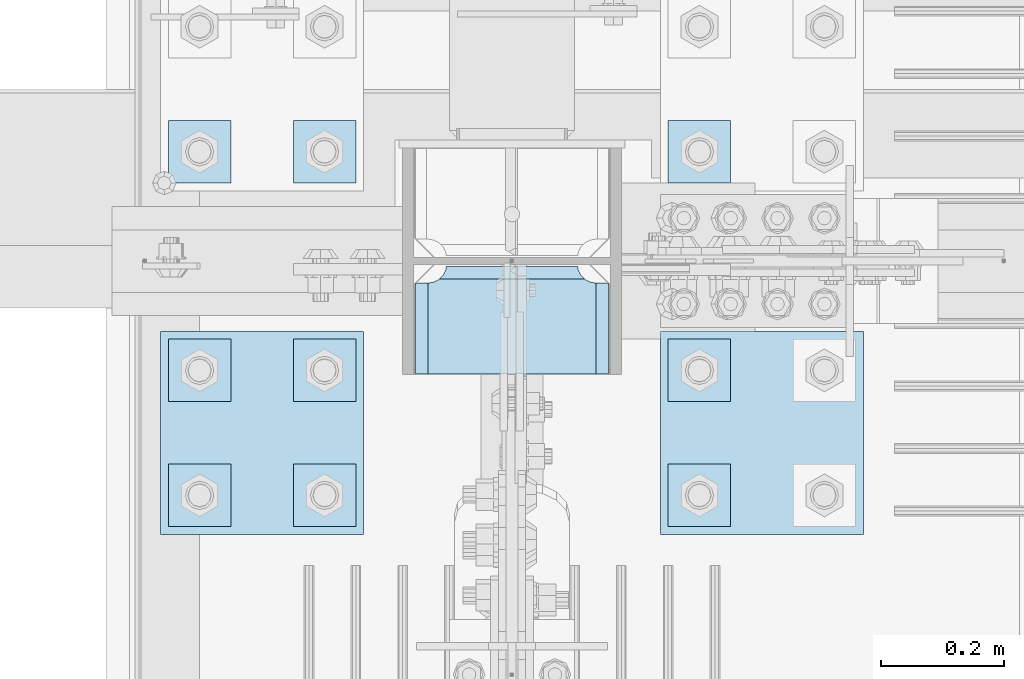
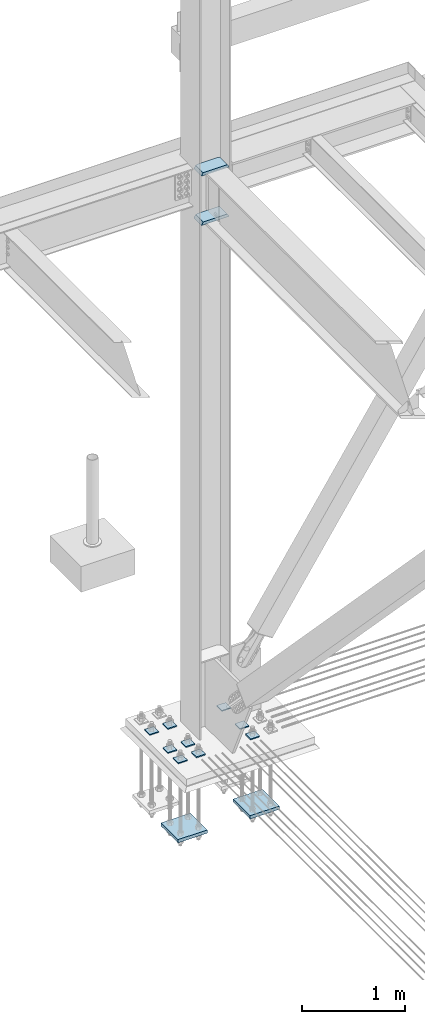
# One storey, part 3539 of 3843: 13 plates, 2 elements without a shape of their own.
"""IFC2X3 building model written with IfcOpenShell, lengths in millimetres."""

from ifc_helpers import new_model, si_unit, frame, origin_with_axes, place, context, subcontext, project, spatial, faceted_brep, material, type_object, element, aggregate, save


model = new_model("IFC2X3")

# Units and contexts
model_context = context("Model", 3, precision=1e-05, world=origin_with_axes())
body_context = subcontext(model_context, "Body", "Model", "MODEL_VIEW")
ifc_project = project(units=[si_unit("LENGTHUNIT", "METRE", prefix="MILLI"), si_unit("AREAUNIT", "SQUARE_METRE"), si_unit("VOLUMEUNIT", "CUBIC_METRE"), si_unit("MASSUNIT", "GRAM", prefix="KILO"), si_unit("TIMEUNIT", "SECOND"), si_unit("PLANEANGLEUNIT", "RADIAN"), si_unit("SOLIDANGLEUNIT", "STERADIAN"), si_unit("THERMODYNAMICTEMPERATUREUNIT", "DEGREE_CELSIUS"), si_unit("LUMINOUSINTENSITYUNIT", "LUMEN")], contexts=[model_context])

# Site, building, storey
site_placement = place(None, origin_with_axes())
site = spatial("IfcSite", under=ifc_project, at=site_placement, CompositionType="ELEMENT")
building_placement = place(site_placement, origin_with_axes())
building = spatial("IfcBuilding", under=site, at=building_placement, Name="Undefined", CompositionType="ELEMENT")
storey_placement = place(building_placement, origin_with_axes())
storey = spatial("IfcBuildingStorey", under=building, at=storey_placement, Name="Undefined", CompositionType="ELEMENT", Elevation=0.0)

# Assembly, plates
assembly_1_placement = place(storey_placement, origin_with_axes())
assembly_1 = element("IfcElementAssembly", 1, at=assembly_1_placement, inside=storey, Name="COLUMN", AssemblyPlace="NOTDEFINED", PredefinedType="RIGID_FRAME")
ifc_material = material(Name="STEEL/A572-50")
plate_type_1 = type_object("IfcPlateType", PredefinedType="NOTDEFINED")
plate_1_placement = place(assembly_1_placement, frame((76852.4625, 104375.74375, 35831.4625), z_axis=(1.0, 0.0, 0.0), x_axis=(0.0, 1.0, 0.0)))
plate_1 = element("IfcPlate", 2, at=plate_1_placement, type_object=plate_type_1, material=ifc_material, Name="PLATE", context=body_context, shape_type="Brep", body=[
    faceted_brep([(160.070930155271, 7.74588927352306, 48.2144734940957), (154.461042336727, 17.4625000000015, 42.6045856755663), (154.461042336727, 17.4625000000015, 278.070402117402), (160.070930155271, 7.74588927353034, 272.460514298873), (168.479277841048, -6.81779612594255, 268.176247164767), (174.625000047687, -17.4625000000015, 267.202860392674), (174.625000047687, -17.4625000000015, 53.472127400295), (168.479277841048, -6.81779612594255, 52.4987406282016), (147.637502670288, 17.4625000000015, 23.3384576632816), (147.637502670288, -17.4625000000015, 3.17449995232164), (0.0, -17.4625000000015, 3.17449995232164), (0.0, 17.4625000000015, 23.3384576632816), (0.0, 17.4625000000015, 297.335542336732), (0.0, -17.4625000000015, 317.499500047692), (147.637502670288, -17.4625000000015, 317.499500047692), (147.637502670288, 17.4625000000015, 297.335542336732), (147.637502670288, -17.4625000000015, 296.862489700317), (147.637502670288, 17.4625000000015, 296.862489700317), (149.113760516208, -17.4625000000015, 287.541764489608), (149.113760516208, 17.4625000000015, 287.541764489608), (153.398027650313, -17.4625000000015, 279.13341680383), (153.398027650313, 17.4625000000015, 279.13341680383), (160.070930155271, -17.4625000000015, 272.460514298873), (168.479277841048, -17.4625000000015, 268.176247164767), (168.479277841048, -17.4625000000015, 52.4987406282016), (160.070930155271, -17.4625000000015, 48.2144734940957), (153.398027650313, -17.4625000000015, 41.5415709891386), (153.398027650313, 17.4625000000015, 41.5415709891386), (149.113760516208, -17.4625000000015, 33.1332233033609), (149.113760516208, 17.4625000000015, 33.1332233033609), (147.637502670288, -17.4625000000015, 23.8124980926514), (147.637502670288, 17.4625000000015, 23.8124980926514)], [[[0, 1, 2, 3, 4, 5, 6, 7]], [[8, 9, 10, 11]], [[12, 13, 14, 15]], [[13, 12, 11, 10]], [[16, 17, 15, 14]], [[16, 18, 19, 17]], [[18, 20, 21, 19]], [[21, 20, 22, 3, 2]], [[22, 23, 4, 3]], [[23, 5, 4]], [[24, 7, 6]], [[24, 25, 0, 7]], [[25, 26, 27, 1, 0]], [[26, 28, 29, 27]], [[28, 30, 31, 29]], [[31, 30, 9, 8]], [[27, 29, 31, 8, 11, 12, 15, 17, 19, 21, 2, 1]], [[9, 30, 28, 26, 25, 24, 6, 5, 23, 22, 20, 18, 16, 14, 13, 10]]]),
])
plate_2_placement = place(assembly_1_placement, frame((76852.4625, 104375.74375, 36418.8375), z_axis=(1.0, 0.0, 0.0), x_axis=(0.0, 1.0, 0.0)))
plate_2 = element("IfcPlate", 3, at=plate_2_placement, type_object=plate_type_1, material=ifc_material, Name="PLATE", context=body_context, shape_type="Brep", body=[
    faceted_brep([(160.070930155271, 7.74588927352306, 48.2144734940957), (154.461042336727, 17.4625000000015, 42.6045856755663), (154.461042336727, 17.4625000000015, 278.070402117402), (160.070930155271, 7.74588927353034, 272.460514298873), (168.479277841048, -6.81779612594255, 268.176247164767), (174.625000047687, -17.4625000000015, 267.202860392674), (174.625000047687, -17.4625000000015, 53.472127400295), (168.479277841048, -6.81779612594255, 52.4987406282016), (147.637502670288, 17.4625000000015, 23.3384576632816), (147.637502670288, -17.4625000000015, 3.17449995232164), (0.0, -17.4625000000015, 3.17449995232164), (0.0, 17.4625000000015, 23.3384576632816), (0.0, 17.4625000000015, 297.335542336732), (0.0, -17.4625000000015, 317.499500047692), (147.637502670288, -17.4625000000015, 317.499500047692), (147.637502670288, 17.4625000000015, 297.335542336732), (147.637502670288, -17.4625000000015, 296.862489700317), (147.637502670288, 17.4625000000015, 296.862489700317), (149.113760516208, -17.4625000000015, 287.541764489608), (149.113760516208, 17.4625000000015, 287.541764489608), (153.398027650313, -17.4625000000015, 279.13341680383), (153.398027650313, 17.4625000000015, 279.13341680383), (160.070930155271, -17.4625000000015, 272.460514298873), (168.479277841048, -17.4625000000015, 268.176247164767), (168.479277841048, -17.4625000000015, 52.4987406282016), (160.070930155271, -17.4625000000015, 48.2144734940957), (153.398027650313, -17.4625000000015, 41.5415709891386), (153.398027650313, 17.4625000000015, 41.5415709891386), (149.113760516208, -17.4625000000015, 33.1332233033609), (149.113760516208, 17.4625000000015, 33.1332233033609), (147.637502670288, -17.4625000000015, 23.8124980926514), (147.637502670288, 17.4625000000015, 23.8124980926514)], [[[0, 1, 2, 3, 4, 5, 6, 7]], [[8, 9, 10, 11]], [[12, 13, 14, 15]], [[13, 12, 11, 10]], [[16, 17, 15, 14]], [[16, 18, 19, 17]], [[18, 20, 21, 19]], [[21, 20, 22, 3, 2]], [[22, 23, 4, 3]], [[23, 5, 4]], [[24, 7, 6]], [[24, 25, 0, 7]], [[25, 26, 27, 1, 0]], [[26, 28, 29, 27]], [[28, 30, 31, 29]], [[31, 30, 9, 8]], [[27, 29, 31, 8, 11, 12, 15, 17, 19, 21, 2, 1]], [[9, 30, 28, 26, 25, 24, 6, 5, 23, 22, 20, 18, 16, 14, 13, 10]]]),
])
aggregate(assembly_1, [plate_1, plate_2])

assembly_2_placement = place(storey_placement, origin_with_axes())
assembly_2 = element("IfcElementAssembly", 4, at=assembly_2_placement, inside=storey, Name="TEMPLATE", AssemblyPlace="NOTDEFINED", PredefinedType="RIGID_FRAME")
plate_type_2 = type_object("IfcPlateType", PredefinedType="NOTDEFINED")
plate_3_placement = place(assembly_2_placement, frame((77266.8, 104228.9, 29698.95), z_axis=(0.0, -1.0, 0.0), x_axis=(1.0, 0.0, 0.0)))
plate_3 = element("IfcPlate", 5, at=plate_3_placement, type_object=plate_type_2, material=ifc_material, Name="Washer Plate", context=body_context, shape_type="Brep", body=[
    faceted_brep([(0.0, -6.3499999046162, 0.0), (-1.67347025126219e-10, -6.35000000000582, 101.600000000151), (-1.67347025126219e-10, 6.35000000000582, 101.600000000151), (7.27595761418343e-12, 6.3499999046162, 0.0), (101.599998474121, -6.34999999999854, 101.599998474121), (101.599998474121, 6.34999999999854, 101.599998474121), (101.6, -6.34999999999854, 0.0), (101.6, 6.34999999999854, 0.0)], [[[0, 1, 2, 3]], [[1, 4, 5, 2]], [[4, 6, 7, 5]], [[6, 0, 3, 7]], [[5, 7, 3, 2]], [[6, 4, 1, 0]]]),
])
plate_4_placement = place(assembly_2_placement, frame((77266.8, 104432.1, 29698.95), z_axis=(0.0, -1.0, 0.0), x_axis=(1.0, 0.0, 0.0)))
plate_4 = element("IfcPlate", 6, at=plate_4_placement, type_object=plate_type_2, material=ifc_material, Name="Washer Plate", context=body_context, shape_type="Brep", body=[
    faceted_brep([(0.0, -6.3499999046162, 0.0), (-1.67347025126219e-10, -6.35000000000582, 101.600000000151), (-1.67347025126219e-10, 6.35000000000582, 101.600000000151), (7.27595761418343e-12, 6.3499999046162, 0.0), (101.599998474121, -6.34999999999854, 101.599998474121), (101.599998474121, 6.34999999999854, 101.599998474121), (101.6, -6.34999999999854, 0.0), (101.6, 6.34999999999854, 0.0)], [[[0, 1, 2, 3]], [[1, 4, 5, 2]], [[4, 6, 7, 5]], [[6, 0, 3, 7]], [[5, 7, 3, 2]], [[6, 4, 1, 0]]]),
])
plate_5_placement = place(assembly_2_placement, frame((77266.8, 104787.7, 29698.95), z_axis=(0.0, -1.0, 0.0), x_axis=(1.0, 0.0, 0.0)))
plate_5 = element("IfcPlate", 7, at=plate_5_placement, type_object=plate_type_2, material=ifc_material, Name="Washer Plate", context=body_context, shape_type="Brep", body=[
    faceted_brep([(0.0, -6.3499999046162, 0.0), (-1.67347025126219e-10, -6.35000000000582, 101.600000000151), (-1.67347025126219e-10, 6.35000000000582, 101.600000000151), (7.27595761418343e-12, 6.3499999046162, 0.0), (101.599998474121, -6.34999999999854, 101.599998474121), (101.599998474121, 6.34999999999854, 101.599998474121), (101.6, -6.34999999999854, 0.0), (101.6, 6.34999999999854, 0.0)], [[[0, 1, 2, 3]], [[1, 4, 5, 2]], [[4, 6, 7, 5]], [[6, 0, 3, 7]], [[5, 7, 3, 2]], [[6, 4, 1, 0]]]),
])
plate_6_placement = place(assembly_2_placement, frame((76657.2, 104228.9, 29698.95), z_axis=(0.0, -1.0, 0.0), x_axis=(1.0, 0.0, 0.0)))
plate_6 = element("IfcPlate", 8, at=plate_6_placement, type_object=plate_type_2, material=ifc_material, Name="Washer Plate", context=body_context, shape_type="Brep", body=[
    faceted_brep([(0.0, -6.3499999046162, 0.0), (-1.67347025126219e-10, -6.35000000000582, 101.600000000151), (-1.67347025126219e-10, 6.35000000000582, 101.600000000151), (7.27595761418343e-12, 6.3499999046162, 0.0), (101.599998474121, -6.34999999999854, 101.599998474121), (101.599998474121, 6.34999999999854, 101.599998474121), (101.6, -6.34999999999854, 0.0), (101.6, 6.34999999999854, 0.0)], [[[0, 1, 2, 3]], [[1, 4, 5, 2]], [[4, 6, 7, 5]], [[6, 0, 3, 7]], [[5, 7, 3, 2]], [[6, 4, 1, 0]]]),
])
plate_7_placement = place(assembly_2_placement, frame((76657.2, 104432.1, 29698.95), z_axis=(0.0, -1.0, 0.0), x_axis=(1.0, 0.0, 0.0)))
plate_7 = element("IfcPlate", 9, at=plate_7_placement, type_object=plate_type_2, material=ifc_material, Name="Washer Plate", context=body_context, shape_type="Brep", body=[
    faceted_brep([(0.0, -6.3499999046162, 0.0), (-1.67347025126219e-10, -6.35000000000582, 101.600000000151), (-1.67347025126219e-10, 6.35000000000582, 101.600000000151), (7.27595761418343e-12, 6.3499999046162, 0.0), (101.599998474121, -6.34999999999854, 101.599998474121), (101.599998474121, 6.34999999999854, 101.599998474121), (101.6, -6.34999999999854, 0.0), (101.6, 6.34999999999854, 0.0)], [[[0, 1, 2, 3]], [[1, 4, 5, 2]], [[4, 6, 7, 5]], [[6, 0, 3, 7]], [[5, 7, 3, 2]], [[6, 4, 1, 0]]]),
])
plate_8_placement = place(assembly_2_placement, frame((76657.2, 104787.7, 29698.95), z_axis=(0.0, -1.0, 0.0), x_axis=(1.0, 0.0, 0.0)))
plate_8 = element("IfcPlate", 10, at=plate_8_placement, type_object=plate_type_2, material=ifc_material, Name="Washer Plate", context=body_context, shape_type="Brep", body=[
    faceted_brep([(0.0, -6.3499999046162, 0.0), (-1.67347025126219e-10, -6.35000000000582, 101.600000000151), (-1.67347025126219e-10, 6.35000000000582, 101.600000000151), (7.27595761418343e-12, 6.3499999046162, 0.0), (101.599998474121, -6.34999999999854, 101.599998474121), (101.599998474121, 6.34999999999854, 101.599998474121), (101.6, -6.34999999999854, 0.0), (101.6, 6.34999999999854, 0.0)], [[[0, 1, 2, 3]], [[1, 4, 5, 2]], [[4, 6, 7, 5]], [[6, 0, 3, 7]], [[5, 7, 3, 2]], [[6, 4, 1, 0]]]),
])
plate_9_placement = place(assembly_2_placement, frame((76454.0, 104228.9, 29698.95), z_axis=(0.0, -1.0, 0.0), x_axis=(1.0, 0.0, 0.0)))
plate_9 = element("IfcPlate", 11, at=plate_9_placement, type_object=plate_type_2, material=ifc_material, Name="Washer Plate", context=body_context, shape_type="Brep", body=[
    faceted_brep([(0.0, -6.3499999046162, 0.0), (-1.67347025126219e-10, -6.35000000000582, 101.600000000151), (-1.67347025126219e-10, 6.35000000000582, 101.600000000151), (7.27595761418343e-12, 6.3499999046162, 0.0), (101.599998474121, -6.34999999999854, 101.599998474121), (101.599998474121, 6.34999999999854, 101.599998474121), (101.6, -6.34999999999854, 0.0), (101.6, 6.34999999999854, 0.0)], [[[0, 1, 2, 3]], [[1, 4, 5, 2]], [[4, 6, 7, 5]], [[6, 0, 3, 7]], [[5, 7, 3, 2]], [[6, 4, 1, 0]]]),
])
plate_10_placement = place(assembly_2_placement, frame((76454.0, 104432.1, 29698.95), z_axis=(0.0, -1.0, 0.0), x_axis=(1.0, 0.0, 0.0)))
plate_10 = element("IfcPlate", 12, at=plate_10_placement, type_object=plate_type_2, material=ifc_material, Name="Washer Plate", context=body_context, shape_type="Brep", body=[
    faceted_brep([(0.0, -6.3499999046162, 0.0), (-1.67347025126219e-10, -6.35000000000582, 101.600000000151), (-1.67347025126219e-10, 6.35000000000582, 101.600000000151), (7.27595761418343e-12, 6.3499999046162, 0.0), (101.599998474121, -6.34999999999854, 101.599998474121), (101.599998474121, 6.34999999999854, 101.599998474121), (101.6, -6.34999999999854, 0.0), (101.6, 6.34999999999854, 0.0)], [[[0, 1, 2, 3]], [[1, 4, 5, 2]], [[4, 6, 7, 5]], [[6, 0, 3, 7]], [[5, 7, 3, 2]], [[6, 4, 1, 0]]]),
])
plate_11_placement = place(assembly_2_placement, frame((76454.0, 104787.7, 29698.95), z_axis=(0.0, -1.0, 0.0), x_axis=(1.0, 0.0, 0.0)))
plate_11 = element("IfcPlate", 13, at=plate_11_placement, type_object=plate_type_2, material=ifc_material, Name="Washer Plate", context=body_context, shape_type="Brep", body=[
    faceted_brep([(0.0, -6.3499999046162, 0.0), (-1.67347025126219e-10, -6.35000000000582, 101.600000000151), (-1.67347025126219e-10, 6.35000000000582, 101.600000000151), (7.27595761418343e-12, 6.3499999046162, 0.0), (101.599998474121, -6.34999999999854, 101.599998474121), (101.599998474121, 6.34999999999854, 101.599998474121), (101.6, -6.34999999999854, 0.0), (101.6, 6.34999999999854, 0.0)], [[[0, 1, 2, 3]], [[1, 4, 5, 2]], [[4, 6, 7, 5]], [[6, 0, 3, 7]], [[5, 7, 3, 2]], [[6, 4, 1, 0]]]),
])
plate_type_3 = type_object("IfcPlateType", PredefinedType="NOTDEFINED")
plate_12_placement = place(assembly_2_placement, frame((76441.3, 104444.800003052, 28784.55), z_axis=(1.0, 0.0, 0.0), x_axis=(0.0, -1.0, 0.0)))
plate_12 = element("IfcPlate", 14, at=plate_12_placement, type_object=plate_type_3, material=ifc_material, Name="PLATE", context=body_context, shape_type="Brep", body=[
    faceted_brep([(0.0, -19.0500000000029, 0.0), (0.0, -19.0499999999993, 330.200012207031), (0.0, 19.0499999999993, 330.200012207031), (0.0, 19.0500000000029, 0.0), (330.200012207031, -19.0499999999993, 330.200012207031), (330.200012207031, 19.0499999999993, 330.200012207031), (330.200012207031, -19.0499999999993, 0.0), (330.200012207031, 19.0499999999993, 0.0)], [[[0, 1, 2, 3]], [[1, 4, 5, 2]], [[4, 6, 7, 5]], [[6, 0, 3, 7]], [[5, 7, 3, 2]], [[6, 4, 1, 0]]]),
])
plate_13_placement = place(assembly_2_placement, frame((77254.1, 104444.800003052, 28784.55), z_axis=(1.0, 0.0, 0.0), x_axis=(0.0, -1.0, 0.0)))
plate_13 = element("IfcPlate", 15, at=plate_13_placement, type_object=plate_type_3, material=ifc_material, Name="PLATE", context=body_context, shape_type="Brep", body=[
    faceted_brep([(0.0, -19.0500000000029, 0.0), (0.0, -19.0499999999993, 330.200012207031), (0.0, 19.0499999999993, 330.200012207031), (0.0, 19.0500000000029, 0.0), (330.200012207031, -19.0499999999993, 330.200012207031), (330.200012207031, 19.0499999999993, 330.200012207031), (330.200012207031, -19.0499999999993, 0.0), (330.200012207031, 19.0499999999993, 0.0)], [[[0, 1, 2, 3]], [[1, 4, 5, 2]], [[4, 6, 7, 5]], [[6, 0, 3, 7]], [[5, 7, 3, 2]], [[6, 4, 1, 0]]]),
])
aggregate(assembly_2, [plate_12, plate_13, plate_3, plate_4, plate_5, plate_6, plate_7, plate_8, plate_9, plate_10, plate_11])

save(model, "model.ifc")
